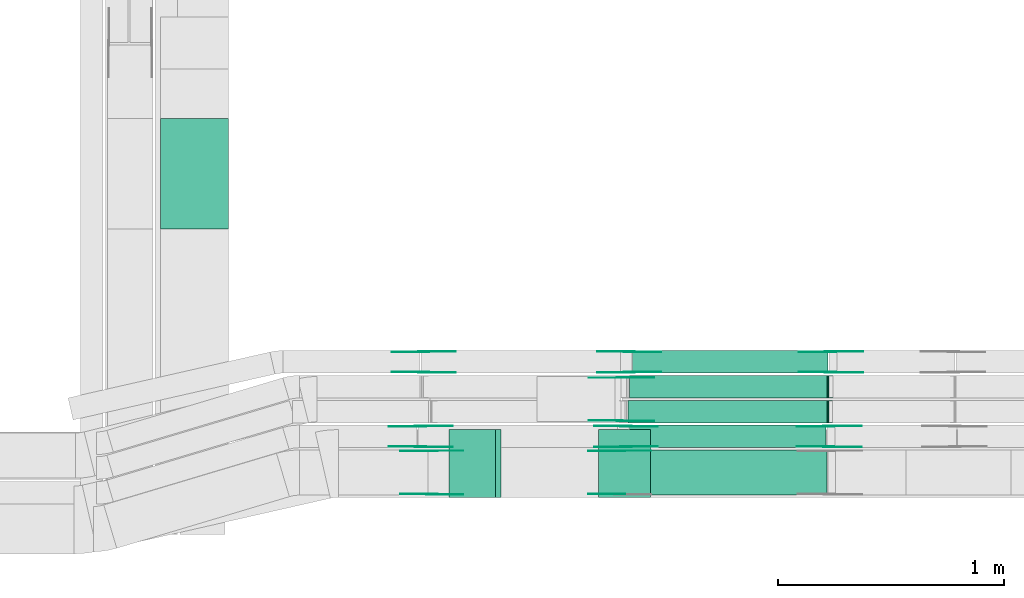
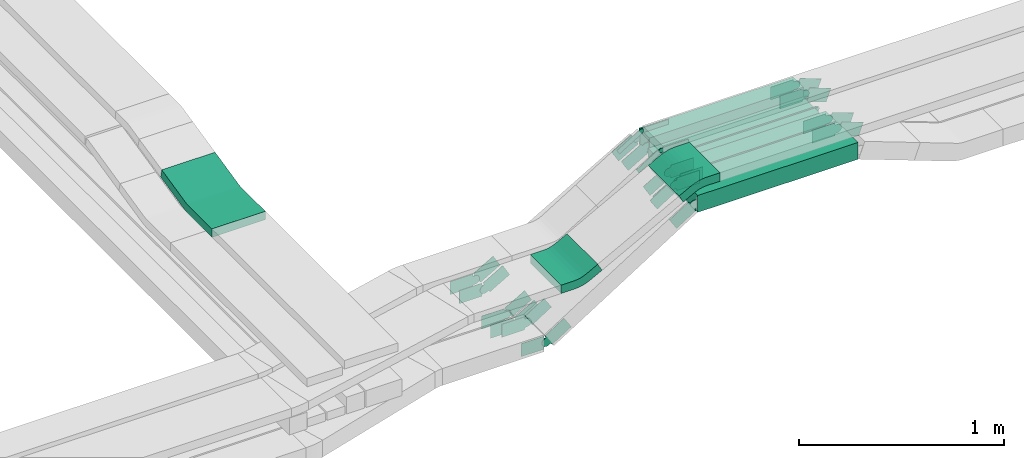
# One storey, part 23 of 28: 40 flow fittings, 5 flow segments.
"""IFC2X3 building model written with IfcOpenShell, lengths in millimetres."""

from ifc_helpers import new_model, entity, si_unit, converted_unit, derived_unit, direction, frame, frame_2d, origin, origin_2d_with_axis, place, context, subcontext, project, spatial, polyline, circle_curve, parameter, trimmed, segment, composite_curve, rectangle, outline, extrude, faceted_brep, source, transform, mapped, material, type_object, type_shapes, element, save


model = new_model("IFC2X3")

# Units and contexts
model_context = context("Model", 3, precision=0.01, world=origin(), true_north=direction((6.12303176911189e-17, 1.0)))
body_context = subcontext(model_context, "Body", "Model", "MODEL_VIEW")
ifc_project = project(units=[si_unit("LENGTHUNIT", "METRE", prefix="MILLI"), si_unit("AREAUNIT", "SQUARE_METRE"), si_unit("VOLUMEUNIT", "CUBIC_METRE"), converted_unit("PLANEANGLEUNIT", "DEGREE", entity("IfcRatioMeasure", 0.0174532925199433), si_unit("PLANEANGLEUNIT", "RADIAN"), dimensions=[0, 0, 0, 0, 0, 0, 0]), si_unit("MASSUNIT", "GRAM", prefix="KILO"), derived_unit("MASSDENSITYUNIT", [(si_unit("MASSUNIT", "GRAM", prefix="KILO"), 1), (si_unit("LENGTHUNIT", "METRE"), -3)]), derived_unit("MOMENTOFINERTIAUNIT", [(si_unit("LENGTHUNIT", "METRE"), 4)]), si_unit("TIMEUNIT", "SECOND"), si_unit("FREQUENCYUNIT", "HERTZ"), si_unit("THERMODYNAMICTEMPERATUREUNIT", "DEGREE_CELSIUS"), derived_unit("THERMALTRANSMITTANCEUNIT", [(si_unit("MASSUNIT", "GRAM", prefix="KILO"), 1), (si_unit("THERMODYNAMICTEMPERATUREUNIT", "KELVIN"), -1), (si_unit("TIMEUNIT", "SECOND"), -3)]), derived_unit("VOLUMETRICFLOWRATEUNIT", [(si_unit("LENGTHUNIT", "METRE"), 3), (si_unit("TIMEUNIT", "SECOND"), -1)]), derived_unit("MASSFLOWRATEUNIT", [(si_unit("MASSUNIT", "GRAM", prefix="KILO"), 1), (si_unit("TIMEUNIT", "SECOND"), -1)]), derived_unit("ROTATIONALFREQUENCYUNIT", [(si_unit("TIMEUNIT", "SECOND"), -1)]), si_unit("ELECTRICCURRENTUNIT", "AMPERE"), si_unit("ELECTRICVOLTAGEUNIT", "VOLT"), si_unit("POWERUNIT", "WATT"), si_unit("FORCEUNIT", "NEWTON", prefix="KILO"), si_unit("ILLUMINANCEUNIT", "LUX"), si_unit("LUMINOUSFLUXUNIT", "LUMEN"), si_unit("LUMINOUSINTENSITYUNIT", "CANDELA"), derived_unit("USERDEFINED", [(si_unit("MASSUNIT", "GRAM", prefix="KILO"), -1), (si_unit("LENGTHUNIT", "METRE"), -2), (si_unit("TIMEUNIT", "SECOND"), 3), (si_unit("LUMINOUSFLUXUNIT", "LUMEN"), 1)]), derived_unit("LINEARVELOCITYUNIT", [(si_unit("LENGTHUNIT", "METRE"), 1), (si_unit("TIMEUNIT", "SECOND"), -1)]), si_unit("PRESSUREUNIT", "PASCAL"), derived_unit("USERDEFINED", [(si_unit("LENGTHUNIT", "METRE"), -2), (si_unit("MASSUNIT", "GRAM", prefix="KILO"), 1), (si_unit("TIMEUNIT", "SECOND"), -2)]), derived_unit("LINEARFORCEUNIT", [(si_unit("MASSUNIT", "GRAM", prefix="KILO"), 1), (si_unit("LENGTHUNIT", "METRE"), 1), (si_unit("TIMEUNIT", "SECOND"), -2), (si_unit("LENGTHUNIT", "METRE"), -1)]), derived_unit("PLANARFORCEUNIT", [(si_unit("MASSUNIT", "GRAM", prefix="KILO"), 1), (si_unit("LENGTHUNIT", "METRE"), 1), (si_unit("TIMEUNIT", "SECOND"), -2), (si_unit("LENGTHUNIT", "METRE"), -2)])], contexts=[model_context])

# Site, building, storey
site_placement = place(None, origin())
site = spatial("IfcSite", under=ifc_project, at=site_placement, CompositionType="ELEMENT")
building_placement = place(site_placement, origin())
building = spatial("IfcBuilding", under=site, at=building_placement, CompositionType="ELEMENT")
storey_placement = place(building_placement, frame((0.0, 0.0, 15900.0)))
storey = spatial("IfcBuildingStorey", under=building, at=storey_placement, CompositionType="ELEMENT", Elevation=15900.0)

# Flow segments
cable_carrier_segment_type = type_object("IfcCableCarrierSegmentType", PredefinedType="CABLETRAYSEGMENT")
flow_segment_1_placement = place(storey_placement, frame((62529.75, 8474.97, 3025.44)))
element("IfcFlowSegment", 1, at=flow_segment_1_placement, inside=storey, type_object=cable_carrier_segment_type, context=body_context, shape_type="SweptSolid", body=[
    extrude(rectangle(XDim=901.526322667125, YDim=200.0, at=origin_2d_with_axis()), frame((450.76, 100.0, 0.0)), (0.0, 0.0, 1.0), 99.9999999999989),
])
flow_segment_2_placement = place(storey_placement, frame((62557.03, 8684.97, 3025.44)))
element("IfcFlowSegment", 2, at=flow_segment_2_placement, inside=storey, type_object=cable_carrier_segment_type, context=body_context, shape_type="SweptSolid", body=[
    extrude(rectangle(XDim=870.814775228981, YDim=100.000000000001, at=origin_2d_with_axis()), frame((435.41, 50.0, 0.0)), (0.0, 0.0, 1.0), 99.9999999999989),
])
flow_segment_3_placement = place(storey_placement, frame((62551.03, 8794.97, 3025.44)))
element("IfcFlowSegment", 3, at=flow_segment_3_placement, inside=storey, type_object=cable_carrier_segment_type, context=body_context, shape_type="SweptSolid", body=[
    extrude(rectangle(XDim=879.269099914084, YDim=100.000000000001, at=origin_2d_with_axis()), frame((439.63, 50.0, 0.0)), (0.0, 0.0, 1.0), 50.0000000000016),
])
flow_segment_4_placement = place(storey_placement, frame((62556.98, 8904.97, 3025.44)))
element("IfcFlowSegment", 4, at=flow_segment_4_placement, inside=storey, type_object=cable_carrier_segment_type, context=body_context, shape_type="SweptSolid", body=[
    extrude(rectangle(XDim=874.16186190821, YDim=100.000000000001, at=origin_2d_with_axis()), frame((437.08, 50.0, 0.0)), (0.0, 0.0, 1.0), 50.0000000000016),
])
flow_segment_5_placement = place(storey_placement, frame((62570.87, 9014.97, 3025.44)))
element("IfcFlowSegment", 5, at=flow_segment_5_placement, inside=storey, type_object=cable_carrier_segment_type, context=body_context, shape_type="SweptSolid", body=[
    extrude(rectangle(XDim=865.233015267495, YDim=100.000000000001, at=origin_2d_with_axis()), frame((432.62, 50.0, 0.0)), (0.0, 0.0, 1.0), 99.9999999999989),
])

# Flow fittings
ifc_material_1 = material()
cable_carrier_fitting_type_1 = type_object("IfcCableCarrierFittingType", PredefinedType="NOTDEFINED", material=ifc_material_1)
shared_shape_1 = source(origin(), body_context, "Body", "Brep", [
    faceted_brep([(-9.04, 25.0, 50.0), (-9.04, 25.0, -50.0), (-9.04, -25.0, -50.0), (-9.04, -25.0, -47.46), (-9.04, 22.46, -47.46), (-9.04, 22.46, 47.46), (-9.04, -25.0, 47.46), (-9.04, -25.0, 50.0), (-0.29, 26.58, 50.0), (17.22, -20.25, 50.0), (17.22, -20.25, 47.46), (0.6, 24.2, 47.46), (0.6, 24.2, -47.46), (17.22, -20.25, -47.46), (17.22, -20.25, -50.0), (-0.29, 26.58, -50.0), (-4.52, 25.0, 50.0), (-4.52, 25.0, -50.0), (4.52, -25.0, -50.0), (4.52, -25.0, -47.46), (-4.06, 22.46, -47.46), (-4.06, 22.46, 47.46), (4.52, -25.0, 47.46), (4.52, -25.0, 50.0)], [[[0, 1, 2, 3, 4, 5, 6, 7]], [[8, 9, 10, 11, 12, 13, 14, 15]], [[1, 0, 16, 17]], [[2, 1, 17, 15, 14, 18]], [[3, 2, 18, 19]], [[4, 3, 19, 13, 12, 20]], [[5, 4, 20, 21]], [[6, 5, 21, 11, 10, 22]], [[7, 6, 22, 23]], [[0, 7, 23, 9, 8, 16]], [[17, 16, 8, 15]], [[19, 18, 14, 13]], [[21, 20, 12, 11]], [[23, 22, 10, 9]]]),
])
type_shapes(cable_carrier_fitting_type_1, [shared_shape_1])
flow_fitting_1_placement = place(storey_placement, frame((63439.33, 8844.97, 3050.44), z_axis=(0.0, 1.0, 0.0), x_axis=(1.0, 0.0, 0.0)))
element("IfcFlowFitting", 6, at=flow_fitting_1_placement, inside=storey, type_object=cable_carrier_fitting_type_1, material=ifc_material_1, context=body_context, shape_type="MappedRepresentation", body=[
    mapped(shared_shape_1, transform((0.0, 0.0, 0.0), scale=1.0)),
])
cable_carrier_fitting_type_2 = type_object("IfcCableCarrierFittingType", PredefinedType="NOTDEFINED", material=ifc_material_1)
shared_shape_2 = source(origin(), body_context, "Body", "Brep", [
    faceted_brep([(-9.05, 25.0, 50.0), (-9.05, 25.0, -50.0), (-9.05, -25.0, -50.0), (-9.05, -25.0, -47.46), (-9.05, 22.46, -47.46), (-9.05, 22.46, 47.46), (-9.05, -25.0, 47.46), (-9.05, -25.0, 50.0), (-0.29, 26.59, 50.0), (17.24, -20.24, 50.0), (17.24, -20.24, 47.46), (0.6, 24.21, 47.46), (0.6, 24.21, -47.46), (17.24, -20.24, -47.46), (17.24, -20.24, -50.0), (-0.29, 26.59, -50.0), (-4.52, 25.0, 50.0), (-4.52, 25.0, -50.0), (4.52, -25.0, -50.0), (4.52, -25.0, -47.46), (-4.06, 22.46, -47.46), (-4.06, 22.46, 47.46), (4.52, -25.0, 47.46), (4.52, -25.0, 50.0)], [[[0, 1, 2, 3, 4, 5, 6, 7]], [[8, 9, 10, 11, 12, 13, 14, 15]], [[1, 0, 16, 17]], [[2, 1, 17, 15, 14, 18]], [[3, 2, 18, 19]], [[4, 3, 19, 13, 12, 20]], [[5, 4, 20, 21]], [[6, 5, 21, 11, 10, 22]], [[7, 6, 22, 23]], [[0, 7, 23, 9, 8, 16]], [[17, 16, 8, 15]], [[19, 18, 14, 13]], [[21, 20, 12, 11]], [[23, 22, 10, 9]]]),
])
type_shapes(cable_carrier_fitting_type_2, [shared_shape_2])
flow_fitting_2_placement = place(storey_placement, frame((63440.19, 8954.97, 3050.44), z_axis=(0.0, 1.0, 0.0), x_axis=(1.0, 0.0, 0.0)))
element("IfcFlowFitting", 7, at=flow_fitting_2_placement, inside=storey, type_object=cable_carrier_fitting_type_2, material=ifc_material_1, context=body_context, shape_type="MappedRepresentation", body=[
    mapped(shared_shape_2, transform((0.0, 0.0, 0.0), scale=1.0)),
])
ifc_material_2 = material(Name="G")
cable_carrier_fitting_type_3 = type_object("IfcCableCarrierFittingType", PredefinedType="NOTDEFINED", material=ifc_material_2)
shared_shape_3 = source(origin(), body_context, "Body", "SweptSolid", [
    extrude(outline(composite_curve([segment(trimmed(circle_curve(frame_2d((-44.59, 0.0), x_axis=(1.0, 0.0)), 12.5), [parameter(90.0000000000007)], [parameter(270.0)], True, "PARAMETER"), True, "CONTINUOUS"), segment(polyline([(-44.59, -12.5), (-33.09, -12.5)]), True, "CONTINUOUS"), segment(polyline([(-33.09, -12.5), (-31.23, -14.5)]), True, "CONTINUOUS"), segment(polyline([(-31.23, -14.5), (108.91, -14.5)]), True, "CONTINUOUS"), segment(polyline([(108.91, -14.5), (108.91, 14.5)]), True, "CONTINUOUS"), segment(polyline([(108.91, 14.5), (-31.23, 14.5)]), True, "CONTINUOUS"), segment(polyline([(-31.23, 14.5), (-33.09, 12.5)]), True, "CONTINUOUS"), segment(polyline([(-33.09, 12.5), (-44.59, 12.5)]), True, "CONTINUOUS")], self_intersect=False)), frame((44.59, 0.0, 0.0), z_axis=(0.0, 0.0, -1.0), x_axis=(1.0, 0.0, 0.0)), (0.0, 0.0, -1.0), 2.0),
])
type_shapes(cable_carrier_fitting_type_3, [shared_shape_3])
flow_fitting_3_placement = place(storey_placement, frame((62513.82, 8995.61, 3200.0), z_axis=(0.0, 1.0, 0.0), x_axis=(1.0, 0.0, 0.0)))
element("IfcFlowFitting", 8, at=flow_fitting_3_placement, inside=storey, type_object=cable_carrier_fitting_type_3, material=ifc_material_2, context=body_context, shape_type="MappedRepresentation", body=[
    mapped(shared_shape_3, transform((0.0, 0.0, 0.0), scale=1.0)),
])
cable_carrier_fitting_type_4 = type_object("IfcCableCarrierFittingType", PredefinedType="NOTDEFINED", material=ifc_material_2)
type_shapes(cable_carrier_fitting_type_4, [shared_shape_3])
flow_fitting_4_placement = place(storey_placement, frame((62513.82, 8806.69, 3200.0), z_axis=(0.0, -1.0, 0.0), x_axis=(-0.851940405089901, 0.0, -0.523638755417564)))
element("IfcFlowFitting", 9, at=flow_fitting_4_placement, inside=storey, type_object=cable_carrier_fitting_type_4, material=ifc_material_2, context=body_context, shape_type="MappedRepresentation", body=[
    mapped(shared_shape_3, transform((0.0, 0.0, 0.0), scale=1.0)),
])
cable_carrier_fitting_type_5 = type_object("IfcCableCarrierFittingType", PredefinedType="NOTDEFINED", material=ifc_material_2)
shared_shape_4 = source(origin(), body_context, "Body", "SweptSolid", [
    extrude(outline(composite_curve([segment(trimmed(circle_curve(frame_2d((-44.59, 0.0), x_axis=(1.0, 0.0)), 12.5), [parameter(90.0000000000007)], [parameter(270.0)], True, "PARAMETER"), True, "CONTINUOUS"), segment(polyline([(-44.59, -12.5), (-33.09, -12.5)]), True, "CONTINUOUS"), segment(polyline([(-33.09, -12.5), (-31.23, -14.5)]), True, "CONTINUOUS"), segment(polyline([(-31.23, -14.5), (108.91, -14.5)]), True, "CONTINUOUS"), segment(polyline([(108.91, -14.5), (108.91, 14.5)]), True, "CONTINUOUS"), segment(polyline([(108.91, 14.5), (-31.23, 14.5)]), True, "CONTINUOUS"), segment(polyline([(-31.23, 14.5), (-33.09, 12.5)]), True, "CONTINUOUS"), segment(polyline([(-33.09, 12.5), (-44.59, 12.5)]), True, "CONTINUOUS")], self_intersect=False)), frame((44.59, 0.0, 0.0)), (0.0, 0.0, 1.0), 2.0),
])
type_shapes(cable_carrier_fitting_type_5, [shared_shape_4])
flow_fitting_5_placement = place(storey_placement, frame((62513.82, 8804.69, 3200.0), z_axis=(0.0, -1.0, 0.0), x_axis=(1.0, 0.0, 0.0)))
element("IfcFlowFitting", 10, at=flow_fitting_5_placement, inside=storey, type_object=cable_carrier_fitting_type_5, material=ifc_material_2, context=body_context, shape_type="MappedRepresentation", body=[
    mapped(shared_shape_4, transform((0.0, 0.0, 0.0), scale=1.0)),
])
cable_carrier_fitting_type_6 = type_object("IfcCableCarrierFittingType", PredefinedType="NOTDEFINED", material=ifc_material_2)
type_shapes(cable_carrier_fitting_type_6, [shared_shape_4])
flow_fitting_6_placement = place(storey_placement, frame((62513.82, 8993.61, 3200.0), z_axis=(0.0, 1.0, 0.0), x_axis=(-0.851940405089901, 0.0, -0.523638755417564)))
element("IfcFlowFitting", 11, at=flow_fitting_6_placement, inside=storey, type_object=cable_carrier_fitting_type_6, material=ifc_material_2, context=body_context, shape_type="MappedRepresentation", body=[
    mapped(shared_shape_4, transform((0.0, 0.0, 0.0), scale=1.0)),
])
cable_carrier_fitting_type_7 = type_object("IfcCableCarrierFittingType", PredefinedType="NOTDEFINED", material=ifc_material_2)
shared_shape_5 = source(origin(), body_context, "Body", "SweptSolid", [
    extrude(outline(composite_curve([segment(trimmed(circle_curve(frame_2d((-41.47, 0.0), x_axis=(1.0, 0.0)), 25.0), [parameter(90.0000000000007)], [parameter(270.0)], True, "PARAMETER"), True, "CONTINUOUS"), segment(polyline([(-41.47, -25.0), (-29.97, -25.0)]), True, "CONTINUOUS"), segment(polyline([(-29.97, -25.0), (-28.1, -38.5)]), True, "CONTINUOUS"), segment(polyline([(-28.1, -38.5), (99.53, -38.5)]), True, "CONTINUOUS"), segment(polyline([(99.53, -38.5), (99.53, 38.5)]), True, "CONTINUOUS"), segment(polyline([(99.53, 38.5), (-28.1, 38.5)]), True, "CONTINUOUS"), segment(polyline([(-28.1, 38.5), (-29.97, 25.0)]), True, "CONTINUOUS"), segment(polyline([(-29.97, 25.0), (-41.47, 25.0)]), True, "CONTINUOUS")], self_intersect=False)), frame((41.47, 0.0, 0.0), z_axis=(0.0, 0.0, -1.0), x_axis=(1.0, 0.0, 0.0)), (0.0, 0.0, -1.0), 2.0),
])
type_shapes(cable_carrier_fitting_type_7, [shared_shape_5])
flow_fitting_7_placement = place(storey_placement, frame((62541.55, 8689.51, 3075.44), z_axis=(0.0, -1.0, 0.0), x_axis=(-0.865893399879645, 0.0, -0.50022856780163)))
element("IfcFlowFitting", 12, at=flow_fitting_7_placement, inside=storey, type_object=cable_carrier_fitting_type_7, material=ifc_material_2, context=body_context, shape_type="MappedRepresentation", body=[
    mapped(shared_shape_5, transform((0.0, 0.0, 0.0), scale=1.0)),
])
cable_carrier_fitting_type_8 = type_object("IfcCableCarrierFittingType", PredefinedType="NOTDEFINED", material=ifc_material_2)
type_shapes(cable_carrier_fitting_type_8, [shared_shape_5])
flow_fitting_8_placement = place(storey_placement, frame((62541.55, 8778.43, 3075.44), z_axis=(0.0, 1.0, 0.0), x_axis=(1.0, 0.0, 0.0)))
element("IfcFlowFitting", 13, at=flow_fitting_8_placement, inside=storey, type_object=cable_carrier_fitting_type_8, material=ifc_material_2, context=body_context, shape_type="MappedRepresentation", body=[
    mapped(shared_shape_5, transform((0.0, 0.0, 0.0), scale=1.0)),
])
flow_fitting_9_placement = place(storey_placement, frame((61632.03, 8689.51, 2550.0), z_axis=(0.0, -1.0, 0.0), x_axis=(0.865893399879645, 0.0, 0.50022856780163)))
element("IfcFlowFitting", 14, at=flow_fitting_9_placement, inside=storey, type_object=cable_carrier_fitting_type_7, material=ifc_material_2, context=body_context, shape_type="MappedRepresentation", body=[
    mapped(shared_shape_5, transform((0.0, 0.0, 0.0), scale=1.0)),
])
flow_fitting_10_placement = place(storey_placement, frame((61632.03, 8778.43, 2550.0), z_axis=(0.0, 1.0, 0.0), x_axis=(-1.0, 0.0, 0.0)))
element("IfcFlowFitting", 15, at=flow_fitting_10_placement, inside=storey, type_object=cable_carrier_fitting_type_8, material=ifc_material_2, context=body_context, shape_type="MappedRepresentation", body=[
    mapped(shared_shape_5, transform((0.0, 0.0, 0.0), scale=1.0)),
])
flow_fitting_11_placement = place(storey_placement, frame((62555.39, 9019.51, 3075.44), z_axis=(0.0, -1.0, 0.0), x_axis=(-0.865893399879645, 0.0, -0.50022856780163)))
element("IfcFlowFitting", 16, at=flow_fitting_11_placement, inside=storey, type_object=cable_carrier_fitting_type_7, material=ifc_material_2, context=body_context, shape_type="MappedRepresentation", body=[
    mapped(shared_shape_5, transform((0.0, 0.0, 0.0), scale=1.0)),
])
flow_fitting_12_placement = place(storey_placement, frame((62555.39, 9108.43, 3075.44), z_axis=(0.0, 1.0, 0.0), x_axis=(1.0, 0.0, 0.0)))
element("IfcFlowFitting", 17, at=flow_fitting_12_placement, inside=storey, type_object=cable_carrier_fitting_type_8, material=ifc_material_2, context=body_context, shape_type="MappedRepresentation", body=[
    mapped(shared_shape_5, transform((0.0, 0.0, 0.0), scale=1.0)),
])
flow_fitting_13_placement = place(storey_placement, frame((61645.86, 9019.51, 2550.0), z_axis=(0.0, -1.0, 0.0), x_axis=(0.865893399879645, 0.0, 0.50022856780163)))
element("IfcFlowFitting", 18, at=flow_fitting_13_placement, inside=storey, type_object=cable_carrier_fitting_type_7, material=ifc_material_2, context=body_context, shape_type="MappedRepresentation", body=[
    mapped(shared_shape_5, transform((0.0, 0.0, 0.0), scale=1.0)),
])
flow_fitting_14_placement = place(storey_placement, frame((61645.86, 9108.43, 2550.0), z_axis=(0.0, 1.0, 0.0), x_axis=(-1.0, 0.0, 0.0)))
element("IfcFlowFitting", 19, at=flow_fitting_14_placement, inside=storey, type_object=cable_carrier_fitting_type_8, material=ifc_material_2, context=body_context, shape_type="MappedRepresentation", body=[
    mapped(shared_shape_5, transform((0.0, 0.0, 0.0), scale=1.0)),
])
flow_fitting_15_placement = place(storey_placement, frame((63438.52, 8780.43, 3075.44), z_axis=(0.0, 1.0, 0.0), x_axis=(0.937801944103825, 0.0, -0.347170726927093)))
element("IfcFlowFitting", 20, at=flow_fitting_15_placement, inside=storey, type_object=cable_carrier_fitting_type_7, material=ifc_material_2, context=body_context, shape_type="MappedRepresentation", body=[
    mapped(shared_shape_5, transform((0.0, 0.0, 0.0), scale=1.0)),
])
flow_fitting_16_placement = place(storey_placement, frame((63438.52, 8691.51, 3075.44), z_axis=(0.0, -1.0, 0.0), x_axis=(-1.0, 0.0, 0.0)))
element("IfcFlowFitting", 21, at=flow_fitting_16_placement, inside=storey, type_object=cable_carrier_fitting_type_8, material=ifc_material_2, context=body_context, shape_type="MappedRepresentation", body=[
    mapped(shared_shape_5, transform((0.0, 0.0, 0.0), scale=1.0)),
])
flow_fitting_17_placement = place(storey_placement, frame((63447.03, 9110.43, 3075.44), z_axis=(0.0, 1.0, 0.0), x_axis=(0.934589453965168, 0.0, -0.355728200368047)))
element("IfcFlowFitting", 22, at=flow_fitting_17_placement, inside=storey, type_object=cable_carrier_fitting_type_7, material=ifc_material_2, context=body_context, shape_type="MappedRepresentation", body=[
    mapped(shared_shape_5, transform((0.0, 0.0, 0.0), scale=1.0)),
])
flow_fitting_18_placement = place(storey_placement, frame((63447.03, 9021.51, 3075.44), z_axis=(0.0, -1.0, 0.0), x_axis=(-1.0, 0.0, 0.0)))
element("IfcFlowFitting", 23, at=flow_fitting_18_placement, inside=storey, type_object=cable_carrier_fitting_type_8, material=ifc_material_2, context=body_context, shape_type="MappedRepresentation", body=[
    mapped(shared_shape_5, transform((0.0, 0.0, 0.0), scale=1.0)),
])
flow_fitting_19_placement = place(storey_placement, frame((61682.03, 8479.51, 2550.0), z_axis=(0.0, -1.0, 0.0), x_axis=(0.845240241928741, 0.0, 0.534386501910596)))
element("IfcFlowFitting", 24, at=flow_fitting_19_placement, inside=storey, type_object=cable_carrier_fitting_type_7, material=ifc_material_2, context=body_context, shape_type="MappedRepresentation", body=[
    mapped(shared_shape_5, transform((0.0, 0.0, 0.0), scale=1.0)),
])
flow_fitting_20_placement = place(storey_placement, frame((61682.03, 8668.43, 2550.0), z_axis=(0.0, 1.0, 0.0), x_axis=(-1.0, 0.0, 0.0)))
element("IfcFlowFitting", 25, at=flow_fitting_20_placement, inside=storey, type_object=cable_carrier_fitting_type_8, material=ifc_material_2, context=body_context, shape_type="MappedRepresentation", body=[
    mapped(shared_shape_5, transform((0.0, 0.0, 0.0), scale=1.0)),
])
flow_fitting_21_placement = place(storey_placement, frame((62513.11, 8670.43, 3075.44), z_axis=(0.0, 1.0, 0.0), x_axis=(1.0, 0.0, 0.0)))
element("IfcFlowFitting", 26, at=flow_fitting_21_placement, inside=storey, type_object=cable_carrier_fitting_type_7, material=ifc_material_2, context=body_context, shape_type="MappedRepresentation", body=[
    mapped(shared_shape_5, transform((0.0, 0.0, 0.0), scale=1.0)),
])
flow_fitting_22_placement = place(storey_placement, frame((62513.11, 8481.51, 3075.44), z_axis=(0.0, -1.0, 0.0), x_axis=(-0.845240241928726, 0.0, -0.53438650191062)))
element("IfcFlowFitting", 27, at=flow_fitting_22_placement, inside=storey, type_object=cable_carrier_fitting_type_8, material=ifc_material_2, context=body_context, shape_type="MappedRepresentation", body=[
    mapped(shared_shape_5, transform((0.0, 0.0, 0.0), scale=1.0)),
])
cable_carrier_fitting_type_9 = type_object("IfcCableCarrierFittingType", PredefinedType="NOTDEFINED", material=ifc_material_2)
shared_shape_6 = source(origin(), body_context, "Body", "SweptSolid", [
    extrude(outline(composite_curve([segment(trimmed(circle_curve(frame_2d((-41.47, 0.0), x_axis=(1.0, 0.0)), 25.0), [parameter(90.0000000000007)], [parameter(270.0)], True, "PARAMETER"), True, "CONTINUOUS"), segment(polyline([(-41.47, -25.0), (-29.97, -25.0)]), True, "CONTINUOUS"), segment(polyline([(-29.97, -25.0), (-28.1, -38.5)]), True, "CONTINUOUS"), segment(polyline([(-28.1, -38.5), (99.53, -38.5)]), True, "CONTINUOUS"), segment(polyline([(99.53, -38.5), (99.53, 38.5)]), True, "CONTINUOUS"), segment(polyline([(99.53, 38.5), (-28.1, 38.5)]), True, "CONTINUOUS"), segment(polyline([(-28.1, 38.5), (-29.97, 25.0)]), True, "CONTINUOUS"), segment(polyline([(-29.97, 25.0), (-41.47, 25.0)]), True, "CONTINUOUS")], self_intersect=False)), frame((41.47, 0.0, 0.0)), (0.0, 0.0, 1.0), 2.0),
])
type_shapes(cable_carrier_fitting_type_9, [shared_shape_6])
flow_fitting_23_placement = place(storey_placement, frame((62541.55, 8780.43, 3075.44), z_axis=(0.0, 1.0, 0.0), x_axis=(-0.865893399879645, 0.0, -0.50022856780163)))
element("IfcFlowFitting", 28, at=flow_fitting_23_placement, inside=storey, type_object=cable_carrier_fitting_type_9, material=ifc_material_2, context=body_context, shape_type="MappedRepresentation", body=[
    mapped(shared_shape_6, transform((0.0, 0.0, 0.0), scale=1.0)),
])
cable_carrier_fitting_type_10 = type_object("IfcCableCarrierFittingType", PredefinedType="NOTDEFINED", material=ifc_material_2)
type_shapes(cable_carrier_fitting_type_10, [shared_shape_6])
flow_fitting_24_placement = place(storey_placement, frame((62541.55, 8691.51, 3075.44), z_axis=(0.0, -1.0, 0.0), x_axis=(1.0, 0.0, 0.0)))
element("IfcFlowFitting", 29, at=flow_fitting_24_placement, inside=storey, type_object=cable_carrier_fitting_type_10, material=ifc_material_2, context=body_context, shape_type="MappedRepresentation", body=[
    mapped(shared_shape_6, transform((0.0, 0.0, 0.0), scale=1.0)),
])
flow_fitting_25_placement = place(storey_placement, frame((61632.03, 8780.43, 2550.0), z_axis=(0.0, 1.0, 0.0), x_axis=(0.865893399879645, 0.0, 0.50022856780163)))
element("IfcFlowFitting", 30, at=flow_fitting_25_placement, inside=storey, type_object=cable_carrier_fitting_type_9, material=ifc_material_2, context=body_context, shape_type="MappedRepresentation", body=[
    mapped(shared_shape_6, transform((0.0, 0.0, 0.0), scale=1.0)),
])
flow_fitting_26_placement = place(storey_placement, frame((61632.03, 8691.51, 2550.0), z_axis=(0.0, -1.0, 0.0), x_axis=(-1.0, 0.0, 0.0)))
element("IfcFlowFitting", 31, at=flow_fitting_26_placement, inside=storey, type_object=cable_carrier_fitting_type_10, material=ifc_material_2, context=body_context, shape_type="MappedRepresentation", body=[
    mapped(shared_shape_6, transform((0.0, 0.0, 0.0), scale=1.0)),
])
flow_fitting_27_placement = place(storey_placement, frame((62555.39, 9110.43, 3075.44), z_axis=(0.0, 1.0, 0.0), x_axis=(-0.865893399879645, 0.0, -0.50022856780163)))
element("IfcFlowFitting", 32, at=flow_fitting_27_placement, inside=storey, type_object=cable_carrier_fitting_type_9, material=ifc_material_2, context=body_context, shape_type="MappedRepresentation", body=[
    mapped(shared_shape_6, transform((0.0, 0.0, 0.0), scale=1.0)),
])
flow_fitting_28_placement = place(storey_placement, frame((62555.39, 9021.51, 3075.44), z_axis=(0.0, -1.0, 0.0), x_axis=(1.0, 0.0, 0.0)))
element("IfcFlowFitting", 33, at=flow_fitting_28_placement, inside=storey, type_object=cable_carrier_fitting_type_10, material=ifc_material_2, context=body_context, shape_type="MappedRepresentation", body=[
    mapped(shared_shape_6, transform((0.0, 0.0, 0.0), scale=1.0)),
])
flow_fitting_29_placement = place(storey_placement, frame((61645.86, 9110.43, 2550.0), z_axis=(0.0, 1.0, 0.0), x_axis=(0.865893399879645, 0.0, 0.50022856780163)))
element("IfcFlowFitting", 34, at=flow_fitting_29_placement, inside=storey, type_object=cable_carrier_fitting_type_9, material=ifc_material_2, context=body_context, shape_type="MappedRepresentation", body=[
    mapped(shared_shape_6, transform((0.0, 0.0, 0.0), scale=1.0)),
])
flow_fitting_30_placement = place(storey_placement, frame((61645.86, 9021.51, 2550.0), z_axis=(0.0, -1.0, 0.0), x_axis=(-1.0, 0.0, 0.0)))
element("IfcFlowFitting", 35, at=flow_fitting_30_placement, inside=storey, type_object=cable_carrier_fitting_type_10, material=ifc_material_2, context=body_context, shape_type="MappedRepresentation", body=[
    mapped(shared_shape_6, transform((0.0, 0.0, 0.0), scale=1.0)),
])
flow_fitting_31_placement = place(storey_placement, frame((63438.52, 8689.51, 3075.44), z_axis=(0.0, -1.0, 0.0), x_axis=(0.937801944103825, 0.0, -0.347170726927093)))
element("IfcFlowFitting", 36, at=flow_fitting_31_placement, inside=storey, type_object=cable_carrier_fitting_type_9, material=ifc_material_2, context=body_context, shape_type="MappedRepresentation", body=[
    mapped(shared_shape_6, transform((0.0, 0.0, 0.0), scale=1.0)),
])
flow_fitting_32_placement = place(storey_placement, frame((63438.52, 8778.43, 3075.44), z_axis=(0.0, 1.0, 0.0), x_axis=(-1.0, 0.0, 0.0)))
element("IfcFlowFitting", 37, at=flow_fitting_32_placement, inside=storey, type_object=cable_carrier_fitting_type_10, material=ifc_material_2, context=body_context, shape_type="MappedRepresentation", body=[
    mapped(shared_shape_6, transform((0.0, 0.0, 0.0), scale=1.0)),
])
flow_fitting_33_placement = place(storey_placement, frame((63447.03, 9019.51, 3075.44), z_axis=(0.0, -1.0, 0.0), x_axis=(0.934589453965168, 0.0, -0.355728200368047)))
element("IfcFlowFitting", 38, at=flow_fitting_33_placement, inside=storey, type_object=cable_carrier_fitting_type_9, material=ifc_material_2, context=body_context, shape_type="MappedRepresentation", body=[
    mapped(shared_shape_6, transform((0.0, 0.0, 0.0), scale=1.0)),
])
flow_fitting_34_placement = place(storey_placement, frame((63447.03, 9108.43, 3075.44), z_axis=(0.0, 1.0, 0.0), x_axis=(-1.0, 0.0, 0.0)))
element("IfcFlowFitting", 39, at=flow_fitting_34_placement, inside=storey, type_object=cable_carrier_fitting_type_10, material=ifc_material_2, context=body_context, shape_type="MappedRepresentation", body=[
    mapped(shared_shape_6, transform((0.0, 0.0, 0.0), scale=1.0)),
])
flow_fitting_35_placement = place(storey_placement, frame((61682.03, 8670.43, 2550.0), z_axis=(0.0, 1.0, 0.0), x_axis=(0.845240241928741, 0.0, 0.534386501910596)))
element("IfcFlowFitting", 40, at=flow_fitting_35_placement, inside=storey, type_object=cable_carrier_fitting_type_9, material=ifc_material_2, context=body_context, shape_type="MappedRepresentation", body=[
    mapped(shared_shape_6, transform((0.0, 0.0, 0.0), scale=1.0)),
])
for number, where, z_axis, x_axis in (
    (41, (61682.03, 8481.51, 2550.0), (0.0, -1.0, 0.0), (-1.0, 0.0, 0.0)),
    (42, (62513.11, 8668.43, 3075.44), (0.0, 1.0, 0.0), (-0.845240241928726, 0.0, -0.53438650191062)),
):
    element("IfcFlowFitting", number, at=place(storey_placement, frame(where, z_axis=z_axis, x_axis=x_axis)), inside=storey, type_object=cable_carrier_fitting_type_10, material=ifc_material_2, context=body_context, shape_type="MappedRepresentation", body=[
        mapped(shared_shape_6, transform((0.0, 0.0, 0.0), scale=1.0)),
    ])
cable_carrier_fitting_type_11 = type_object("IfcCableCarrierFittingType", Name="470_DKC_S5_CS 90 internal vertical angle:-", PredefinedType="NOTDEFINED", material=ifc_material_1)
shared_shape_7 = source(origin(), body_context, "Body", "SweptSolid", [
    extrude(outline(composite_curve([segment(polyline([(-248.69, -39.69), (-14.02, -39.69)]), True, "CONTINUOUS"), segment(trimmed(circle_curve(frame_2d((-14.02, 125.31), x_axis=(0.0, -1.0)), 164.999999999999), [parameter(0.0)], [parameter(12.7651639618241)], True, "PARAMETER"), True, "CONTINUOUS"), segment(polyline([(22.44, -35.61), (251.31, 16.24)]), True, "CONTINUOUS"), segment(polyline([(251.31, 16.24), (240.26, 65.0)]), True, "CONTINUOUS"), segment(polyline([(240.26, 65.0), (11.39, 13.15)]), True, "CONTINUOUS"), segment(trimmed(circle_curve(frame_2d((-14.02, 125.31), x_axis=(0.0, -1.0)), 114.999999999999), [parameter(0.0)], [parameter(12.7651639618241)], True, "PARAMETER"), False, "CONTINUOUS"), segment(polyline([(-14.02, 10.31), (-248.69, 10.31)]), True, "CONTINUOUS"), segment(polyline([(-248.69, 10.31), (-248.69, -39.69)]), True, "CONTINUOUS")], self_intersect=False)), frame((-1.64, 14.69, -150.0)), (0.0, 0.0, 1.0), 300.0),
])
type_shapes(cable_carrier_fitting_type_11, [shared_shape_7])
flow_fitting_36_placement = place(storey_placement, frame((60630.82, 9903.62, 2905.0), z_axis=(1.0, 0.0, 0.0), x_axis=(0.0, 1.0, 0.0)))
element("IfcFlowFitting", 43, at=flow_fitting_36_placement, inside=storey, type_object=cable_carrier_fitting_type_11, material=ifc_material_1, Name="470_DKC_S5_CS 90 internal vertical angle:-", ObjectType="470_DKC_S5_CS 90 internal vertical angle:-", context=body_context, shape_type="MappedRepresentation", body=[
    mapped(shared_shape_7, transform((0.0, 0.0, 0.0), scale=1.0)),
])
cable_carrier_fitting_type_12 = type_object("IfcCableCarrierFittingType", Name="470_DKC_S5_CD 90 external vertical angle:-", PredefinedType="NOTDEFINED", material=ifc_material_1)
shared_shape_8 = source(origin(), body_context, "Body", "SweptSolid", [
    extrude(outline(composite_curve([segment(polyline([(-111.3, -43.63), (-36.82, -43.63)]), True, "CONTINUOUS"), segment(trimmed(circle_curve(frame_2d((-36.82, 146.37), x_axis=(0.0, -1.0)), 189.999999999999), [parameter(0.0)], [parameter(28.2423935397996)], True, "PARAMETER"), True, "CONTINUOUS"), segment(polyline([(53.09, -21.01), (118.7, 14.23)]), True, "CONTINUOUS"), segment(polyline([(118.7, 14.23), (95.04, 58.28)]), True, "CONTINUOUS"), segment(polyline([(95.04, 58.28), (29.43, 23.03)]), True, "CONTINUOUS"), segment(trimmed(circle_curve(frame_2d((-36.82, 146.37), x_axis=(0.0, -1.0)), 139.999999999999), [parameter(0.0)], [parameter(28.2423935397996)], True, "PARAMETER"), False, "CONTINUOUS"), segment(polyline([(-36.82, 6.37), (-111.3, 6.37)]), True, "CONTINUOUS"), segment(polyline([(-111.3, 6.37), (-111.3, -43.63)]), True, "CONTINUOUS")], self_intersect=False)), frame((-4.69, 18.63, -150.0)), (0.0, 0.0, 1.0), 300.0),
])
type_shapes(cable_carrier_fitting_type_12, [shared_shape_8])
for number, where, z_axis, x_axis, name in (
    (44, (61872.92, 8615.15, 2845.0), (0.0, -1.0, 0.0), (1.0, 0.0, 0.0), "470_DKC_S5_CD 90 external vertical angle:-"),
    (45, (62533.82, 8615.15, 3200.0), (0.0, 1.0, 0.0), (0.880953567308313, 0.0, 0.473202717919876), "470_DKC_S5_CD 90 external vertical angle:-"),
):
    element("IfcFlowFitting", number, at=place(storey_placement, frame(where, z_axis=z_axis, x_axis=x_axis)), inside=storey, type_object=cable_carrier_fitting_type_12, material=ifc_material_1, Name=name, ObjectType="470_DKC_S5_CD 90 external vertical angle:-", context=body_context, shape_type="MappedRepresentation", body=[
        mapped(shared_shape_8, transform((0.0, 0.0, 0.0), scale=1.0)),
    ])

save(model, "model.ifc")
